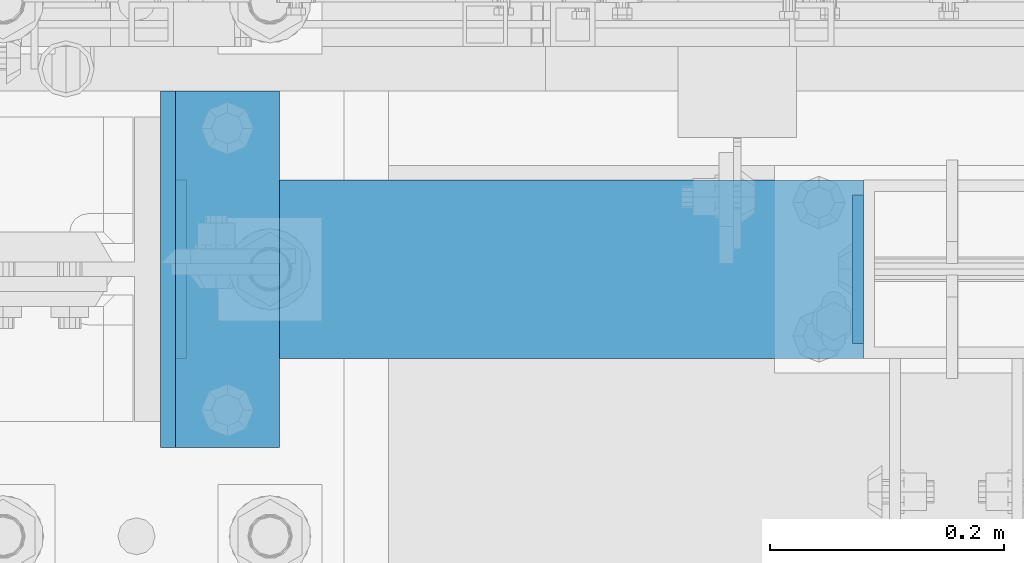
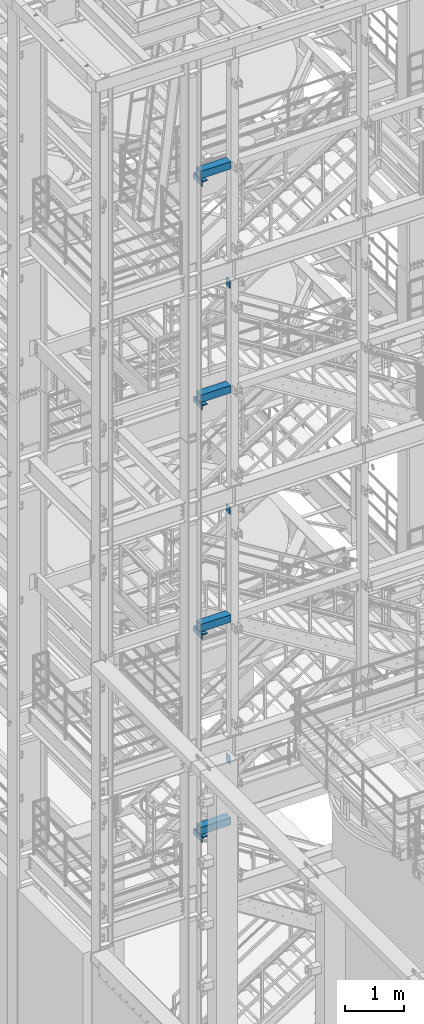
# One storey, part 1126 of 1876: 16 beams, 9 elements without a shape of their own.
"""IFC2X3 building model written with IfcOpenShell, lengths in millimetres."""

from ifc_helpers import new_model, si_unit, frame, origin_with_axes, place, context, subcontext, project, spatial, faceted_brep, material, type_object, element, aggregate, save


model = new_model("IFC2X3")

# Units and contexts
model_context = context("Model", 3, precision=1e-05, world=origin_with_axes())
body_context = subcontext(model_context, "Body", "Model", "MODEL_VIEW")
ifc_project = project(units=[si_unit("LENGTHUNIT", "METRE", prefix="MILLI"), si_unit("AREAUNIT", "SQUARE_METRE"), si_unit("VOLUMEUNIT", "CUBIC_METRE"), si_unit("MASSUNIT", "GRAM", prefix="KILO"), si_unit("TIMEUNIT", "SECOND"), si_unit("PLANEANGLEUNIT", "RADIAN"), si_unit("SOLIDANGLEUNIT", "STERADIAN"), si_unit("THERMODYNAMICTEMPERATUREUNIT", "DEGREE_CELSIUS"), si_unit("LUMINOUSINTENSITYUNIT", "LUMEN")], contexts=[model_context])

# Site, building, storey
site_placement = place(None, origin_with_axes())
site = spatial("IfcSite", under=ifc_project, at=site_placement, CompositionType="ELEMENT")
building_placement = place(site_placement, origin_with_axes())
building = spatial("IfcBuilding", under=site, at=building_placement, Name="Undefined", CompositionType="ELEMENT")
storey_placement = place(building_placement, origin_with_axes())
storey = spatial("IfcBuildingStorey", under=building, at=storey_placement, Name="Undefined", CompositionType="ELEMENT", Elevation=0.0)

# Assembly, beams
assembly_1_placement = place(storey_placement, origin_with_axes())
assembly_1 = element("IfcElementAssembly", 1, at=assembly_1_placement, inside=storey, Name="FRAME", AssemblyPlace="NOTDEFINED", PredefinedType="RIGID_FRAME")
ifc_material_1 = material(Name="STEEL/A36")
beam_type_1 = type_object("IfcBeamType", PredefinedType="NOTDEFINED")
beam_1_placement = place(assembly_1_placement, frame((1879.59999980927, -7188.2, 19958.05), z_axis=(0.0, 0.0, 1.0), x_axis=(0.0, 1.0, 0.0)))
beam_1 = element("IfcBeam", 2, at=beam_1_placement, type_object=beam_type_1, material=ifc_material_1, Name="PLATE", context=body_context, shape_type="Brep", body=[
    faceted_brep([(0.0, 4.76249999999982, -76.1999999999998), (3.63797880709171e-12, 4.76249999999982, 76.1999969482422), (152.399993896484, 4.76250000000073, 76.1999969482422), (152.4, 4.76249999999982, -76.1999999999998), (3.63797880709171e-12, -4.76249999999982, 76.1999969482422), (152.399993896484, -4.76250000000073, 76.1999969482422), (0.0, -4.76249999999982, -76.1999999999998), (152.4, -4.76249999999982, -76.1999999999998)], [[[0, 1, 2, 3]], [[4, 5, 2, 1]], [[4, 6, 7, 5]], [[6, 0, 3, 7]], [[5, 7, 3, 2]], [[6, 4, 1, 0]]]),
])
beam_type_2 = type_object("IfcBeamType", PredefinedType="NOTDEFINED")
beam_2_placement = place(assembly_1_placement, frame((1919.28749980926, -7264.4, 19877.0875), z_axis=(1.0, 0.0, 0.0), x_axis=(0.0, 1.0, 0.0)))
beam_2 = element("IfcBeam", 3, at=beam_2_placement, type_object=beam_type_2, material=ifc_material_1, Name="PLATE", context=body_context, shape_type="Brep", body=[
    faceted_brep([(0.0, 4.76250000000073, -44.4499999999998), (0.0, 4.76250000000073, 44.4499999999998), (304.799999999999, 4.76250000000073, 44.4499999999998), (304.799999999999, 4.76250000000073, -44.4499999999998), (0.0, -4.76250000000073, 44.4499999999998), (304.799999999999, -4.76250000000073, 44.4499999999998), (0.0, -4.76250000000073, -44.4499999999998), (304.799999999999, -4.76250000000073, -44.4499999999998)], [[[0, 1, 2, 3]], [[1, 4, 5, 2]], [[4, 6, 7, 5]], [[6, 0, 3, 7]], [[5, 7, 3, 2]], [[6, 4, 1, 0]]]),
])

# Assembly, beam
assembly_2_placement = place(storey_placement, origin_with_axes())
assembly_2 = element("IfcElementAssembly", 4, at=assembly_2_placement, inside=storey, Name="FRAME", AssemblyPlace="NOTDEFINED", PredefinedType="RIGID_FRAME")
beam_3_placement = place(assembly_2_placement, frame((1919.28749980926, -7264.4, 15254.2875), z_axis=(1.0, 0.0, 0.0), x_axis=(0.0, 1.0, 0.0)))
beam_3 = element("IfcBeam", 5, at=beam_3_placement, type_object=beam_type_2, material=ifc_material_1, Name="PLATE", context=body_context, shape_type="Brep", body=[
    faceted_brep([(0.0, 4.76250000000073, -44.4499999999998), (0.0, 4.76250000000073, 44.4499999999998), (304.799999999999, 4.76250000000073, 44.4499999999998), (304.799999999999, 4.76250000000073, -44.4499999999998), (0.0, -4.76250000000073, 44.4499999999998), (304.799999999999, -4.76250000000073, 44.4499999999998), (0.0, -4.76250000000073, -44.4499999999998), (304.799999999999, -4.76250000000073, -44.4499999999998)], [[[0, 1, 2, 3]], [[1, 4, 5, 2]], [[4, 6, 7, 5]], [[6, 0, 3, 7]], [[5, 7, 3, 2]], [[6, 4, 1, 0]]]),
])

assembly_3_placement = place(storey_placement, origin_with_axes())
assembly_3 = element("IfcElementAssembly", 6, at=assembly_3_placement, inside=storey, Name="FRAME", AssemblyPlace="NOTDEFINED", PredefinedType="RIGID_FRAME")
beam_4_placement = place(assembly_3_placement, frame((1919.26825746042, -7264.4, 10517.1875), z_axis=(1.0, 0.0, 0.0), x_axis=(0.0, 1.0, 0.0)))
beam_4 = element("IfcBeam", 7, at=beam_4_placement, type_object=beam_type_2, material=ifc_material_1, Name="PLATE", context=body_context, shape_type="Brep", body=[
    faceted_brep([(0.0, 4.76250000000073, -44.4499999999998), (0.0, 4.76250000000073, 44.4499999999998), (304.799999999999, 4.76250000000073, 44.4499999999998), (304.799999999999, 4.76250000000073, -44.4499999999998), (0.0, -4.76250000000073, 44.4499999999998), (304.799999999999, -4.76250000000073, 44.4499999999998), (0.0, -4.76250000000073, -44.4499999999998), (304.799999999999, -4.76250000000073, -44.4499999999998)], [[[0, 1, 2, 3]], [[1, 4, 5, 2]], [[4, 6, 7, 5]], [[6, 0, 3, 7]], [[5, 7, 3, 2]], [[6, 4, 1, 0]]]),
])

assembly_4_placement = place(storey_placement, origin_with_axes())
assembly_4 = element("IfcElementAssembly", 8, at=assembly_4_placement, inside=storey, Name="FRAME", AssemblyPlace="NOTDEFINED", PredefinedType="RIGID_FRAME")
beam_5_placement = place(assembly_4_placement, frame((1919.26825746042, -7264.4, 6326.18751063849), z_axis=(1.0, 0.0, 0.0), x_axis=(0.0, 1.0, 0.0)))
beam_5 = element("IfcBeam", 9, at=beam_5_placement, type_object=beam_type_2, material=ifc_material_1, Name="PLATE", context=body_context, shape_type="Brep", body=[
    faceted_brep([(0.0, 4.76250000000073, -44.4499999999998), (0.0, 4.76250000000073, 44.4499999999998), (304.799999999999, 4.76250000000073, 44.4499999999998), (304.799999999999, 4.76250000000073, -44.4499999999998), (0.0, -4.76250000000073, 44.4499999999998), (304.799999999999, -4.76250000000073, 44.4499999999998), (0.0, -4.76250000000073, -44.4499999999998), (304.799999999999, -4.76250000000073, -44.4499999999998)], [[[0, 1, 2, 3]], [[1, 4, 5, 2]], [[4, 6, 7, 5]], [[6, 0, 3, 7]], [[5, 7, 3, 2]], [[6, 4, 1, 0]]]),
])

# Assembly, beams
assembly_5_placement = place(storey_placement, origin_with_axes())
assembly_5 = element("IfcElementAssembly", 10, at=assembly_5_placement, inside=storey, Name="COLUMN", AssemblyPlace="NOTDEFINED", PredefinedType="RIGID_FRAME")
beam_type_3 = type_object("IfcBeamType", Name="L4X4X3/8", PredefinedType="NOTDEFINED")
beam_6_placement = place(assembly_5_placement, frame((1912.93749980926, -7264.4, 19821.525), z_axis=(1.0, 0.0, 0.0), x_axis=(0.0, 1.0, 0.0)))
beam_6 = element("IfcBeam", 11, at=beam_6_placement, type_object=beam_type_3, material=ifc_material_1, Name="ANGLE", ObjectType="L4X4X3/8", context=body_context, shape_type="Brep", body=[
    faceted_brep([(0.0, 50.7999999999993, -50.8000000000002), (0.0, 50.7999999999993, 50.8000000000002), (304.799999999999, 50.7999999999993, 50.8000000000002), (304.799999999999, 50.7999999999993, -50.8000000000002), (0.0, 41.2750000000015, 50.8000000000002), (304.799999999999, 41.2750000000015, 50.8000000000002), (0.0, 41.2750000000015, -41.2749999999996), (304.799999999999, 41.2750000000015, -41.2749999999996), (0.0, -50.7999999999993, -41.2749999999996), (304.799999999999, -50.7999999999993, -41.2749999999996), (0.0, -50.7999999999993, -50.8000000000002), (304.799999999999, -50.7999999999993, -50.8000000000002)], [[[0, 1, 2, 3]], [[1, 4, 5, 2]], [[4, 6, 7, 5]], [[6, 8, 9, 7]], [[8, 10, 11, 9]], [[10, 0, 3, 11]], [[5, 7, 9, 11, 3, 2]], [[10, 8, 6, 4, 1, 0]]]),
])
beam_7_placement = place(assembly_5_placement, frame((1912.93749980926, -7264.4, 15198.725), z_axis=(1.0, 0.0, 0.0), x_axis=(0.0, 1.0, 0.0)))
beam_7 = element("IfcBeam", 12, at=beam_7_placement, type_object=beam_type_3, material=ifc_material_1, Name="ANGLE", ObjectType="L4X4X3/8", context=body_context, shape_type="Brep", body=[
    faceted_brep([(0.0, 50.7999999999993, -50.8000000000002), (0.0, 50.7999999999993, 50.8000000000002), (304.799999999999, 50.7999999999993, 50.8000000000002), (304.799999999999, 50.7999999999993, -50.8000000000002), (0.0, 41.2750000000015, 50.8000000000002), (304.799999999999, 41.2750000000015, 50.8000000000002), (0.0, 41.2750000000015, -41.2749999999996), (304.799999999999, 41.2750000000015, -41.2749999999996), (0.0, -50.7999999999993, -41.2749999999996), (304.799999999999, -50.7999999999993, -41.2749999999996), (0.0, -50.7999999999993, -50.8000000000002), (304.799999999999, -50.7999999999993, -50.8000000000002)], [[[0, 1, 2, 3]], [[1, 4, 5, 2]], [[4, 6, 7, 5]], [[6, 8, 9, 7]], [[8, 10, 11, 9]], [[10, 0, 3, 11]], [[5, 7, 9, 11, 3, 2]], [[10, 8, 6, 4, 1, 0]]]),
])
aggregate(assembly_5, [beam_6, beam_7])

assembly_6_placement = place(storey_placement, origin_with_axes())
assembly_6 = element("IfcElementAssembly", 13, at=assembly_6_placement, inside=storey, Name="COLUMN", AssemblyPlace="NOTDEFINED", PredefinedType="RIGID_FRAME")
beam_8_placement = place(assembly_6_placement, frame((1912.91825746042, -7264.4, 10461.625), z_axis=(1.0, 0.0, 0.0), x_axis=(0.0, 1.0, 0.0)))
beam_8 = element("IfcBeam", 14, at=beam_8_placement, type_object=beam_type_3, material=ifc_material_1, Name="ANGLE", ObjectType="L4X4X3/8", context=body_context, shape_type="Brep", body=[
    faceted_brep([(0.0, 50.7999999999993, -50.8000000000002), (0.0, 50.7999999999993, 50.8000000000002), (304.799999999999, 50.7999999999993, 50.8000000000002), (304.799999999999, 50.7999999999993, -50.8000000000002), (0.0, 41.2750000000015, 50.8000000000002), (304.799999999999, 41.2750000000015, 50.8000000000002), (0.0, 41.2750000000015, -41.2749999999996), (304.799999999999, 41.2750000000015, -41.2749999999996), (0.0, -50.7999999999993, -41.2749999999996), (304.799999999999, -50.7999999999993, -41.2749999999996), (0.0, -50.7999999999993, -50.8000000000002), (304.799999999999, -50.7999999999993, -50.8000000000002)], [[[0, 1, 2, 3]], [[1, 4, 5, 2]], [[4, 6, 7, 5]], [[6, 8, 9, 7]], [[8, 10, 11, 9]], [[10, 0, 3, 11]], [[5, 7, 9, 11, 3, 2]], [[10, 8, 6, 4, 1, 0]]]),
])
beam_9_placement = place(assembly_6_placement, frame((1912.91825746042, -7264.4, 6270.62501063849), z_axis=(1.0, 0.0, 0.0), x_axis=(0.0, 1.0, 0.0)))
beam_9 = element("IfcBeam", 15, at=beam_9_placement, type_object=beam_type_3, material=ifc_material_1, Name="ANGLE", ObjectType="L4X4X3/8", context=body_context, shape_type="Brep", body=[
    faceted_brep([(0.0, 50.7999999999993, -50.8000000000002), (0.0, 50.7999999999993, 50.8000000000002), (304.799999999999, 50.7999999999993, 50.8000000000002), (304.799999999999, 50.7999999999993, -50.8000000000002), (0.0, 41.2750000000015, 50.8000000000002), (304.799999999999, 41.2750000000015, 50.8000000000002), (0.0, 41.2750000000015, -41.2749999999996), (304.799999999999, 41.2750000000015, -41.2749999999996), (0.0, -50.7999999999993, -41.2749999999996), (304.799999999999, -50.7999999999993, -41.2749999999996), (0.0, -50.7999999999993, -50.8000000000002), (304.799999999999, -50.7999999999993, -50.8000000000002)], [[[0, 1, 2, 3]], [[1, 4, 5, 2]], [[4, 6, 7, 5]], [[6, 8, 9, 7]], [[8, 10, 11, 9]], [[10, 0, 3, 11]], [[5, 7, 9, 11, 3, 2]], [[10, 8, 6, 4, 1, 0]]]),
])
aggregate(assembly_6, [beam_8, beam_9])

# Beam
ifc_material_2 = material()
beam_type_4 = type_object("IfcBeamType", Name="HSS6X6X3/8", PredefinedType="NOTDEFINED")
beam_10_placement = place(assembly_1_placement, frame((1874.83749980926, -7112.0, 19958.05), z_axis=(0.0, 1.0, 0.0), x_axis=(1.0, 0.0, 0.0)))
beam_10 = element("IfcBeam", 16, at=beam_10_placement, type_object=beam_type_4, material=ifc_material_2, Name="BEAM", ObjectType="HSS6X6X3/8", context=body_context, shape_type="Brep", body=[
    faceted_brep([(9.52500000000168, 66.6749999999993, -66.6750000000002), (9.52500000000168, -66.6749999999993, -66.6750000000002), (588.962500190737, -66.6749999999993, -66.6750000000002), (588.962500190737, 66.6749999999993, -66.6750000000002), (9.52500000000168, -66.6749999999993, 66.6750000000002), (588.962500190737, -66.6749999999993, 66.6750000000002), (9.52500000000168, 66.6749999999993, 66.6750000000002), (588.962500190737, 66.6749999999993, 66.6750000000002), (9.52500000000168, 76.2000000000007, -76.1999999999998), (9.52500000000168, 76.2000000000007, 76.1999999999998), (588.962500190737, 76.2000000000007, 76.1999999999998), (588.962500190737, 76.2000000000007, -76.1999999999998), (9.52500000000168, -76.2000000000007, 76.1999999999998), (588.962500190737, -76.2000000000007, 76.1999999999998), (9.52500000000168, -76.2000000000007, -76.1999999999998), (588.962500190737, -76.2000000000007, -76.1999999999998)], [[[0, 1, 2, 3]], [[1, 4, 5, 2]], [[4, 6, 7, 5]], [[6, 0, 3, 7]], [[8, 9, 10, 11]], [[9, 12, 13, 10]], [[12, 14, 15, 13]], [[14, 8, 11, 15]], [[13, 15, 11, 10], [5, 7, 3, 2]], [[14, 12, 9, 8], [6, 4, 1, 0]]]),
])

aggregate(assembly_1, [beam_1, beam_2, beam_10])

beam_11_placement = place(assembly_2_placement, frame((1874.83749980926, -7112.0, 15335.25), z_axis=(0.0, 1.0, 0.0), x_axis=(1.0, 0.0, 0.0)))
beam_11 = element("IfcBeam", 17, at=beam_11_placement, type_object=beam_type_4, material=ifc_material_2, Name="BEAM", ObjectType="HSS6X6X3/8", context=body_context, shape_type="Brep", body=[
    faceted_brep([(9.52500000000168, 66.6749999999993, -66.6750000000002), (9.52500000000168, -66.6749999999993, -66.6750000000002), (588.962500190737, -66.6749999999993, -66.6750000000002), (588.962500190737, 66.6749999999993, -66.6750000000002), (9.52500000000168, -66.6749999999993, 66.6750000000002), (588.962500190737, -66.6749999999993, 66.6750000000002), (9.52500000000168, 66.6749999999993, 66.6750000000002), (588.962500190737, 66.6749999999993, 66.6750000000002), (9.52500000000168, 76.2000000000007, -76.1999999999998), (9.52500000000168, 76.2000000000007, 76.1999999999998), (588.962500190737, 76.2000000000007, 76.1999999999998), (588.962500190737, 76.2000000000007, -76.1999999999998), (9.52500000000168, -76.2000000000007, 76.1999999999998), (588.962500190737, -76.2000000000007, 76.1999999999998), (9.52500000000168, -76.2000000000007, -76.1999999999998), (588.962500190737, -76.2000000000007, -76.1999999999998)], [[[0, 1, 2, 3]], [[1, 4, 5, 2]], [[4, 6, 7, 5]], [[6, 0, 3, 7]], [[8, 9, 10, 11]], [[9, 12, 13, 10]], [[12, 14, 15, 13]], [[14, 8, 11, 15]], [[13, 15, 11, 10], [5, 7, 3, 2]], [[14, 12, 9, 8], [6, 4, 1, 0]]]),
])

aggregate(assembly_2, [beam_3, beam_11])

beam_12_placement = place(assembly_3_placement, frame((1874.83749980926, -7112.0, 10598.15), z_axis=(0.0, 1.0, 0.0), x_axis=(1.0, 0.0, 0.0)))
beam_12 = element("IfcBeam", 18, at=beam_12_placement, type_object=beam_type_4, material=ifc_material_2, Name="BEAM", ObjectType="HSS6X6X3/8", context=body_context, shape_type="Brep", body=[
    faceted_brep([(9.52500000000168, 66.6749999999993, -66.6750000000002), (9.52500000000168, -66.6749999999993, -66.6750000000002), (588.962500190737, -66.6749999999993, -66.6750000000002), (588.962500190737, 66.6749999999993, -66.6750000000002), (9.52500000000168, -66.6749999999993, 66.6750000000002), (588.962500190737, -66.6749999999993, 66.6750000000002), (9.52500000000168, 66.6749999999993, 66.6750000000002), (588.962500190737, 66.6749999999993, 66.6750000000002), (9.52500000000168, 76.2000000000007, -76.1999999999998), (9.52500000000168, 76.2000000000007, 76.1999999999998), (588.962500190737, 76.2000000000007, 76.1999999999998), (588.962500190737, 76.2000000000007, -76.1999999999998), (9.52500000000168, -76.2000000000007, 76.1999999999998), (588.962500190737, -76.2000000000007, 76.1999999999998), (9.52500000000168, -76.2000000000007, -76.1999999999998), (588.962500190737, -76.2000000000007, -76.1999999999998)], [[[0, 1, 2, 3]], [[1, 4, 5, 2]], [[4, 6, 7, 5]], [[6, 0, 3, 7]], [[8, 9, 10, 11]], [[9, 12, 13, 10]], [[12, 14, 15, 13]], [[14, 8, 11, 15]], [[13, 15, 11, 10], [5, 7, 3, 2]], [[14, 12, 9, 8], [6, 4, 1, 0]]]),
])

aggregate(assembly_3, [beam_4, beam_12])

beam_13_placement = place(assembly_4_placement, frame((1874.81825726968, -7112.0, 6407.15001063848), z_axis=(0.0, 1.0, 0.0), x_axis=(1.0, 0.0, 0.0)))
beam_13 = element("IfcBeam", 19, at=beam_13_placement, type_object=beam_type_4, material=ifc_material_2, Name="BEAM", ObjectType="HSS6X6X3/8", context=body_context, shape_type="Brep", body=[
    faceted_brep([(9.52500000000168, 66.6749999999993, -66.6750000000002), (9.52500000000168, -66.6749999999993, -66.6750000000002), (588.981742730316, -66.6750000000002, -66.6750000000002), (588.981742730316, 66.6750000000002, -66.6750000000002), (9.52500000000168, -66.6749999999993, 66.6750000000002), (588.981742730316, -66.6750000000002, 66.6750000000002), (9.52500000000168, 66.6749999999993, 66.6750000000002), (588.981742730316, 66.6750000000002, 66.6750000000002), (9.52500000000168, 76.2000000000007, -76.1999999999998), (9.52500000000168, 76.2000000000007, 76.1999999999998), (588.981742730316, 76.1999999999998, 76.1999999999998), (588.981742730316, 76.1999999999998, -76.1999999999998), (9.52500000000168, -76.2000000000007, 76.1999999999998), (588.981742730316, -76.1999999999998, 76.1999999999998), (9.52500000000168, -76.2000000000007, -76.1999999999998), (588.981742730316, -76.1999999999998, -76.1999999999998)], [[[0, 1, 2, 3]], [[1, 4, 5, 2]], [[4, 6, 7, 5]], [[6, 0, 3, 7]], [[8, 9, 10, 11]], [[9, 12, 13, 10]], [[12, 14, 15, 13]], [[14, 8, 11, 15]], [[13, 15, 11, 10], [5, 7, 3, 2]], [[14, 12, 9, 8], [6, 4, 1, 0]]]),
])

aggregate(assembly_4, [beam_5, beam_13])

# Assembly, beam
assembly_7_placement = place(storey_placement, origin_with_axes())
assembly_7 = element("IfcElementAssembly", 20, at=assembly_7_placement, inside=storey, Name="BEAM", AssemblyPlace="NOTDEFINED", PredefinedType="RIGID_FRAME")
beam_type_5 = type_object("IfcBeamType", PredefinedType="NOTDEFINED")
beam_14_placement = place(assembly_7_placement, frame((2459.0375, -7048.5, 7661.275), z_axis=(0.0, 0.0, -1.0), x_axis=(0.0, -1.0, 0.0)))
beam_14 = element("IfcBeam", 21, at=beam_14_placement, type_object=beam_type_5, material=ifc_material_1, Name="PLATE", context=body_context, shape_type="Brep", body=[
    faceted_brep([(0.0, 4.76249999999982, -82.5499999999993), (0.0, 4.76249999999982, 82.5499999999993), (127.0, 4.76249999999982, 82.5499999999993), (127.0, 4.76249999999982, -82.5499999999993), (0.0, -4.76249999999982, 82.5499999999993), (127.0, -4.76249999999982, 82.5499999999993), (0.0, -4.76249999999982, -82.5499999999993), (127.0, -4.76249999999982, -82.5499999999993)], [[[0, 1, 2, 3]], [[1, 4, 5, 2]], [[4, 6, 7, 5]], [[6, 0, 3, 7]], [[5, 7, 3, 2]], [[6, 4, 1, 0]]]),
])
aggregate(assembly_7, [beam_14])

assembly_8_placement = place(storey_placement, origin_with_axes())
assembly_8 = element("IfcElementAssembly", 22, at=assembly_8_placement, inside=storey, Name="BEAM", AssemblyPlace="NOTDEFINED", PredefinedType="RIGID_FRAME")
beam_15_placement = place(assembly_8_placement, frame((2459.0375, -7048.5, 12817.475), z_axis=(0.0, 0.0, -1.0), x_axis=(0.0, -1.0, 0.0)))
beam_15 = element("IfcBeam", 23, at=beam_15_placement, type_object=beam_type_5, material=ifc_material_1, Name="PLATE", context=body_context, shape_type="Brep", body=[
    faceted_brep([(0.0, 4.76249999999982, -82.5499999999993), (0.0, 4.76249999999982, 82.5499999999993), (127.0, 4.76249999999982, 82.5499999999993), (127.0, 4.76249999999982, -82.5499999999993), (0.0, -4.76249999999982, 82.5499999999993), (127.0, -4.76249999999982, 82.5499999999993), (0.0, -4.76249999999982, -82.5499999999993), (127.0, -4.76249999999982, -82.5499999999993)], [[[0, 1, 2, 3]], [[1, 4, 5, 2]], [[4, 6, 7, 5]], [[6, 0, 3, 7]], [[5, 7, 3, 2]], [[6, 4, 1, 0]]]),
])
aggregate(assembly_8, [beam_15])

assembly_9_placement = place(storey_placement, origin_with_axes())
assembly_9 = element("IfcElementAssembly", 24, at=assembly_9_placement, inside=storey, Name="BEAM", AssemblyPlace="NOTDEFINED", PredefinedType="RIGID_FRAME")
beam_16_placement = place(assembly_9_placement, frame((2459.0375, -7048.5, 17491.075), z_axis=(0.0, 0.0, -1.0), x_axis=(0.0, -1.0, 0.0)))
beam_16 = element("IfcBeam", 25, at=beam_16_placement, type_object=beam_type_5, material=ifc_material_1, Name="PLATE", context=body_context, shape_type="Brep", body=[
    faceted_brep([(0.0, 4.76249999999982, -82.5499999999993), (0.0, 4.76249999999982, 82.5499999999993), (127.0, 4.76249999999982, 82.5499999999993), (127.0, 4.76249999999982, -82.5499999999993), (0.0, -4.76249999999982, 82.5499999999993), (127.0, -4.76249999999982, 82.5499999999993), (0.0, -4.76249999999982, -82.5499999999993), (127.0, -4.76249999999982, -82.5499999999993)], [[[0, 1, 2, 3]], [[1, 4, 5, 2]], [[4, 6, 7, 5]], [[6, 0, 3, 7]], [[5, 7, 3, 2]], [[6, 4, 1, 0]]]),
])
aggregate(assembly_9, [beam_16])

save(model, "model.ifc")
